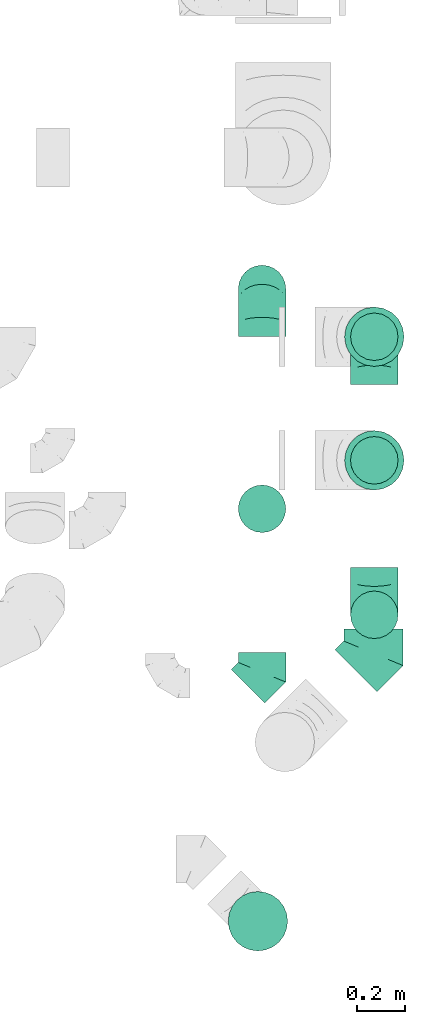
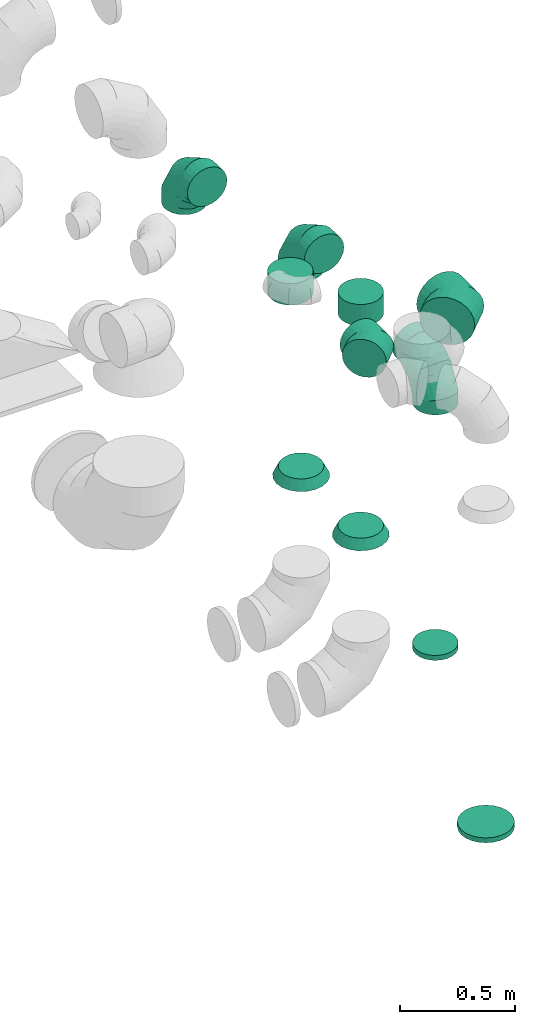
# One storey, part 47 of 59: 11 flow fittings.
"""IFC2X3 building model written with IfcOpenShell, lengths in millimetres."""

from ifc_helpers import new_model, entity, si_unit, converted_unit, derived_unit, direction, frame, origin, place, context, subcontext, project, spatial, faceted_brep, source, transform, mapped, material, type_object, type_shapes, element, save


model = new_model("IFC2X3")

# Units and contexts
model_context = context("Model", 3, precision=0.01, world=origin(), true_north=direction((6.12303176911189e-17, 1.0)))
body_context = subcontext(model_context, "Body", "Model", "MODEL_VIEW")
ifc_project = project(units=[si_unit("LENGTHUNIT", "METRE", prefix="MILLI"), si_unit("AREAUNIT", "SQUARE_METRE"), si_unit("VOLUMEUNIT", "CUBIC_METRE"), converted_unit("PLANEANGLEUNIT", "DEGREE", entity("IfcRatioMeasure", 0.0174532925199433), si_unit("PLANEANGLEUNIT", "RADIAN"), dimensions=[0, 0, 0, 0, 0, 0, 0]), si_unit("MASSUNIT", "GRAM", prefix="KILO"), derived_unit("MASSDENSITYUNIT", [(si_unit("MASSUNIT", "GRAM", prefix="KILO"), 1), (si_unit("LENGTHUNIT", "METRE"), -3)]), derived_unit("MOMENTOFINERTIAUNIT", [(si_unit("LENGTHUNIT", "METRE"), 4)]), si_unit("TIMEUNIT", "SECOND"), si_unit("FREQUENCYUNIT", "HERTZ"), si_unit("THERMODYNAMICTEMPERATUREUNIT", "DEGREE_CELSIUS"), derived_unit("THERMALTRANSMITTANCEUNIT", [(si_unit("MASSUNIT", "GRAM", prefix="KILO"), 1), (si_unit("THERMODYNAMICTEMPERATUREUNIT", "KELVIN"), -1), (si_unit("TIMEUNIT", "SECOND"), -3)]), derived_unit("VOLUMETRICFLOWRATEUNIT", [(si_unit("LENGTHUNIT", "METRE"), 3), (si_unit("TIMEUNIT", "SECOND"), -1)]), derived_unit("MASSFLOWRATEUNIT", [(si_unit("MASSUNIT", "GRAM", prefix="KILO"), 1), (si_unit("TIMEUNIT", "SECOND"), -1)]), derived_unit("ROTATIONALFREQUENCYUNIT", [(si_unit("TIMEUNIT", "SECOND"), -1)]), si_unit("ELECTRICCURRENTUNIT", "AMPERE"), si_unit("ELECTRICVOLTAGEUNIT", "VOLT"), si_unit("POWERUNIT", "WATT"), si_unit("FORCEUNIT", "NEWTON", prefix="KILO"), si_unit("ILLUMINANCEUNIT", "LUX"), si_unit("LUMINOUSFLUXUNIT", "LUMEN"), si_unit("LUMINOUSINTENSITYUNIT", "CANDELA"), derived_unit("USERDEFINED", [(si_unit("MASSUNIT", "GRAM", prefix="KILO"), -1), (si_unit("LENGTHUNIT", "METRE"), -2), (si_unit("TIMEUNIT", "SECOND"), 3), (si_unit("LUMINOUSFLUXUNIT", "LUMEN"), 1)]), derived_unit("LINEARVELOCITYUNIT", [(si_unit("LENGTHUNIT", "METRE"), 1), (si_unit("TIMEUNIT", "SECOND"), -1)]), si_unit("PRESSUREUNIT", "PASCAL"), derived_unit("USERDEFINED", [(si_unit("LENGTHUNIT", "METRE"), -2), (si_unit("MASSUNIT", "GRAM", prefix="KILO"), 1), (si_unit("TIMEUNIT", "SECOND"), -2)]), derived_unit("LINEARFORCEUNIT", [(si_unit("MASSUNIT", "GRAM", prefix="KILO"), 1), (si_unit("LENGTHUNIT", "METRE"), 1), (si_unit("TIMEUNIT", "SECOND"), -2), (si_unit("LENGTHUNIT", "METRE"), -1)]), derived_unit("PLANARFORCEUNIT", [(si_unit("MASSUNIT", "GRAM", prefix="KILO"), 1), (si_unit("LENGTHUNIT", "METRE"), 1), (si_unit("TIMEUNIT", "SECOND"), -2), (si_unit("LENGTHUNIT", "METRE"), -2)])], contexts=[model_context])

# Site, building, storey
site_placement = place(None, origin())
site = spatial("IfcSite", under=ifc_project, at=site_placement, CompositionType="ELEMENT")
building_placement = place(site_placement, origin())
building = spatial("IfcBuilding", under=site, at=building_placement, CompositionType="ELEMENT")
storey_placement = place(building_placement, frame((0.0, 0.0, 28200.0)))
storey = spatial("IfcBuildingStorey", under=building, at=storey_placement, CompositionType="ELEMENT", Elevation=28200.0)

# Flow fittings
ifc_material = material()
duct_fitting_type_1 = type_object("IfcDuctFittingType", PredefinedType="NOTDEFINED", material=ifc_material)
shared_shape_1 = source(origin(), body_context, "Body", "Brep", [
    faceted_brep([(20.0, 32.35, -120.74), (20.0, 62.5, -108.25), (20.0, 88.39, -88.39), (20.0, 108.25, -62.5), (20.0, 120.74, -32.35), (20.0, 125.0, 0.0), (20.0, 120.74, 32.35), (20.0, 108.25, 62.5), (20.0, 88.39, 88.39), (20.0, 62.5, 108.25), (20.0, 32.35, 120.74), (20.0, 0.0, 125.0), (20.0, -32.35, 120.74), (20.0, -62.5, 108.25), (20.0, -88.39, 88.39), (20.0, -108.25, 62.5), (20.0, -120.74, 32.35), (20.0, -125.0, 0.0), (20.0, -120.74, -32.35), (20.0, -108.25, -62.5), (20.0, -88.39, -88.39), (20.0, -62.5, -108.25), (20.0, -32.35, -120.74), (20.0, 0.0, -125.0), (0.0, 0.0, 125.0), (0.0, 32.35, 120.74), (-6.1, 32.35, 120.74), (-6.1, 0.0, 125.0), (0.0, 62.5, 108.25), (-6.1, 62.5, 108.25), (0.0, 88.39, 88.39), (-6.1, 88.39, 88.39), (0.0, 108.25, 62.5), (0.0, 120.74, 32.35), (-6.1, 120.74, 32.35), (-6.1, 108.25, 62.5), (0.0, 125.0, 0.0), (-6.1, 125.0, 0.0), (0.0, 120.74, -32.35), (-6.1, 120.74, -32.35), (0.0, 108.25, -62.5), (-6.1, 108.25, -62.5), (0.0, 88.39, -88.39), (-6.1, 88.39, -88.39), (0.0, 62.5, -108.25), (0.0, 32.35, -120.74), (-6.1, 32.35, -120.74), (-6.1, 62.5, -108.25), (0.0, 0.0, -125.0), (-6.1, 0.0, -125.0), (0.0, -32.35, -120.74), (-6.1, -32.35, -120.74), (0.0, -62.5, -108.25), (-6.1, -62.5, -108.25), (0.0, -88.39, -88.39), (-6.1, -88.39, -88.39), (0.0, -108.25, -62.5), (0.0, -120.74, -32.35), (-6.1, -120.74, -32.35), (-6.1, -108.25, -62.5), (0.0, -125.0, 0.0), (-6.1, -125.0, 0.0), (0.0, -120.74, 32.35), (-6.1, -120.74, 32.35), (0.0, -108.25, 62.5), (-6.1, -108.25, 62.5), (0.0, -88.39, 88.39), (-6.1, -88.39, 88.39), (0.0, -62.5, 108.25), (0.0, -32.35, 120.74), (-6.1, -32.35, 120.74), (-6.1, -62.5, 108.25)], [[[0, 1, 2, 3, 4, 5, 6, 7, 8, 9, 10, 11, 12, 13, 14, 15, 16, 17, 18, 19, 20, 21, 22, 23]], [[24, 11, 10, 25, 26, 27]], [[25, 10, 9, 28, 29, 26]], [[28, 9, 8, 30, 31, 29]], [[32, 7, 6, 33, 34, 35]], [[33, 6, 5, 36, 37, 34]], [[30, 8, 7, 32, 35, 31]], [[36, 5, 4, 38, 39, 37]], [[38, 4, 3, 40, 41, 39]], [[40, 3, 2, 42, 43, 41]], [[44, 1, 0, 45, 46, 47]], [[45, 0, 23, 48, 49, 46]], [[42, 2, 1, 44, 47, 43]], [[48, 23, 22, 50, 51, 49]], [[50, 22, 21, 52, 53, 51]], [[52, 21, 20, 54, 55, 53]], [[56, 19, 18, 57, 58, 59]], [[57, 18, 17, 60, 61, 58]], [[54, 20, 19, 56, 59, 55]], [[60, 17, 16, 62, 63, 61]], [[62, 16, 15, 64, 65, 63]], [[64, 15, 14, 66, 67, 65]], [[68, 13, 12, 69, 70, 71]], [[69, 12, 11, 24, 27, 70]], [[66, 14, 13, 68, 71, 67]], [[49, 51, 53, 55, 59, 58, 61, 63, 65, 67, 71, 70, 27, 26, 29, 31, 35, 34, 37, 39, 41, 43, 47, 46]]]),
])
type_shapes(duct_fitting_type_1, [shared_shape_1])
flow_fitting_1_placement = place(storey_placement, frame((72605.18, 8046.98, 1100.0), z_axis=(0.707106781186531, -0.707106781186564, 0.0), x_axis=(0.0, 0.0, 1.0)))
element("IfcFlowFitting", 1, at=flow_fitting_1_placement, inside=storey, type_object=duct_fitting_type_1, material=ifc_material, context=body_context, shape_type="MappedRepresentation", body=[
    mapped(shared_shape_1, transform((0.0, 0.0, 0.0), scale=1.0)),
])
duct_fitting_type_2 = type_object("IfcDuctFittingType", PredefinedType="NOTDEFINED", material=ifc_material)
shared_shape_2 = source(origin(), body_context, "Body", "Brep", [
    faceted_brep([(-200.0, 0.0, -100.0), (-200.0, -25.88, -96.59), (-200.0, -50.0, -86.6), (-200.0, -70.71, -70.71), (-200.0, -86.6, -50.0), (-200.0, -96.59, -25.88), (-200.0, -100.0, 0.0), (-200.0, -96.59, 25.88), (-200.0, -86.6, 50.0), (-200.0, -70.71, 70.71), (-200.0, -50.0, 86.6), (-200.0, -25.88, 96.59), (-200.0, 0.0, 100.0), (-200.0, 25.88, 96.59), (-200.0, 50.0, 86.6), (-200.0, 70.71, 70.71), (-200.0, 86.6, 50.0), (-200.0, 96.59, 25.88), (-200.0, 100.0, 0.0), (-200.0, 96.59, -25.88), (-200.0, 86.6, -50.0), (-200.0, 70.71, -70.71), (-200.0, 50.0, -86.6), (-200.0, 25.88, -96.59), (-153.35, 25.88, 96.59), (-159.81, 50.0, 86.6), (-146.41, 0.0, 100.0), (-165.36, 70.71, 70.71), (-172.29, 96.59, 25.88), (-173.21, 100.0, 0.0), (-169.62, 86.6, 50.0), (-169.62, 86.6, -50.0), (-165.36, 70.71, -70.71), (-172.29, 96.59, -25.88), (-153.35, 25.88, -96.59), (-146.41, 0.0, -100.0), (-159.81, 50.0, -86.6), (-139.48, -25.88, -96.59), (-133.01, -50.0, -86.6), (-127.46, -70.71, -70.71), (-123.21, -86.6, -50.0), (-120.53, -96.59, -25.88), (-119.62, -100.0, 0.0), (-120.53, -96.59, 25.88), (-123.21, -86.6, 50.0), (-127.46, -70.71, 70.71), (-133.01, -50.0, 86.6), (-139.48, -25.88, 96.59), (-72.54, 72.54, 96.59), (-90.19, 90.19, 86.6), (-53.59, 53.59, 100.0), (-105.35, 105.35, 70.71), (-116.99, 116.99, 50.0), (-124.3, 124.3, 25.88), (-126.79, 126.79, 0.0), (-124.3, 124.3, -25.88), (-116.99, 116.99, -50.0), (-105.35, 105.35, -70.71), (-72.54, 72.54, -96.59), (-53.59, 53.59, -100.0), (-90.19, 90.19, -86.6), (-34.64, 34.64, -96.59), (-16.99, 16.99, -86.6), (-1.83, 1.83, -70.71), (9.81, -9.81, -50.0), (17.12, -17.12, -25.88), (19.62, -19.62, 0.0), (17.12, -17.12, 25.88), (9.81, -9.81, 50.0), (-1.83, 1.83, 70.71), (-16.99, 16.99, 86.6), (-34.64, 34.64, 96.59), (-25.88, 153.35, 96.59), (-50.0, 159.81, 86.6), (0.0, 146.41, 100.0), (-70.71, 165.36, 70.71), (-86.6, 169.62, 50.0), (-96.59, 172.29, 25.88), (-100.0, 173.21, 0.0), (-96.59, 172.29, -25.88), (-86.6, 169.62, -50.0), (-70.71, 165.36, -70.71), (-25.88, 153.35, -96.59), (0.0, 146.41, -100.0), (-50.0, 159.81, -86.6), (25.88, 139.48, -96.59), (50.0, 133.01, -86.6), (70.71, 127.46, -70.71), (86.6, 123.21, -50.0), (96.59, 120.53, -25.88), (100.0, 119.62, 0.0), (96.59, 120.53, 25.88), (86.6, 123.21, 50.0), (70.71, 127.46, 70.71), (50.0, 133.01, 86.6), (25.88, 139.48, 96.59), (-25.88, 200.0, -96.59), (-50.0, 200.0, -86.6), (-70.71, 200.0, -70.71), (-86.6, 200.0, -50.0), (-96.59, 200.0, -25.88), (-100.0, 200.0, 0.0), (-96.59, 200.0, 25.88), (-86.6, 200.0, 50.0), (-70.71, 200.0, 70.71), (-50.0, 200.0, 86.6), (-25.88, 200.0, 96.59), (0.0, 200.0, 100.0), (25.88, 200.0, 96.59), (50.0, 200.0, 86.6), (70.71, 200.0, 70.71), (86.6, 200.0, 50.0), (96.59, 200.0, 25.88), (100.0, 200.0, 0.0), (96.59, 200.0, -25.88), (86.6, 200.0, -50.0), (70.71, 200.0, -70.71), (50.0, 200.0, -86.6), (25.88, 200.0, -96.59), (0.0, 200.0, -100.0)], [[[0, 1, 2, 3, 4, 5, 6, 7, 8, 9, 10, 11, 12, 13, 14, 15, 16, 17, 18, 19, 20, 21, 22, 23]], [[24, 25, 14, 13]], [[26, 24, 13, 12]], [[14, 25, 27, 15]], [[28, 29, 18, 17]], [[30, 28, 17, 16]], [[15, 27, 30, 16]], [[20, 31, 32, 21]], [[33, 31, 20, 19]], [[18, 29, 33, 19]], [[34, 35, 0, 23]], [[36, 34, 23, 22]], [[32, 36, 22, 21]], [[1, 0, 35, 37]], [[2, 1, 37, 38]], [[38, 39, 3, 2]], [[5, 4, 40, 41]], [[6, 5, 41, 42]], [[39, 40, 4, 3]], [[6, 42, 43, 7]], [[7, 43, 44, 8]], [[8, 44, 45, 9]], [[9, 45, 46, 10]], [[10, 46, 47, 11]], [[26, 12, 11, 47]], [[48, 49, 25, 24]], [[50, 48, 24, 26]], [[27, 25, 49, 51]], [[52, 53, 28, 30]], [[51, 52, 30, 27]], [[29, 28, 53, 54]], [[55, 56, 31, 33]], [[54, 55, 33, 29]], [[32, 31, 56, 57]], [[58, 59, 35, 34]], [[60, 58, 34, 36]], [[57, 60, 36, 32]], [[37, 35, 59, 61]], [[38, 37, 61, 62]], [[39, 38, 62, 63]], [[41, 40, 64, 65]], [[42, 41, 65, 66]], [[63, 64, 40, 39]], [[43, 42, 66, 67]], [[44, 43, 67, 68]], [[68, 69, 45, 44]], [[46, 45, 69, 70]], [[47, 46, 70, 71]], [[26, 47, 71, 50]], [[72, 73, 49, 48]], [[74, 72, 48, 50]], [[51, 49, 73, 75]], [[76, 77, 53, 52]], [[75, 76, 52, 51]], [[54, 53, 77, 78]], [[79, 80, 56, 55]], [[78, 79, 55, 54]], [[57, 56, 80, 81]], [[82, 83, 59, 58]], [[84, 82, 58, 60]], [[81, 84, 60, 57]], [[61, 59, 83, 85]], [[62, 61, 85, 86]], [[63, 62, 86, 87]], [[65, 64, 88, 89]], [[66, 65, 89, 90]], [[87, 88, 64, 63]], [[67, 66, 90, 91]], [[68, 67, 91, 92]], [[92, 93, 69, 68]], [[70, 69, 93, 94]], [[71, 70, 94, 95]], [[50, 71, 95, 74]], [[96, 97, 98, 99, 100, 101, 102, 103, 104, 105, 106, 107, 108, 109, 110, 111, 112, 113, 114, 115, 116, 117, 118, 119]], [[72, 74, 107, 106]], [[73, 72, 106, 105]], [[75, 73, 105, 104]], [[102, 101, 78, 77]], [[103, 102, 77, 76]], [[75, 104, 103, 76]], [[78, 101, 100, 79]], [[79, 100, 99, 80]], [[80, 99, 98, 81]], [[84, 97, 96, 82]], [[82, 96, 119, 83]], [[84, 81, 98, 97]], [[118, 117, 86, 85]], [[119, 118, 85, 83]], [[116, 87, 86, 117]], [[88, 115, 114, 89]], [[89, 114, 113, 90]], [[115, 88, 87, 116]], [[91, 90, 113, 112]], [[92, 91, 112, 111]], [[111, 110, 93, 92]], [[95, 94, 109, 108]], [[74, 95, 108, 107]], [[110, 109, 94, 93]]]),
])
type_shapes(duct_fitting_type_2, [shared_shape_2])
for number, where, z_axis, x_axis in (
    (2, (72622.63, 10707.48, 3000.0), (-1.0, 0.0, 0.0), (0.0, 1.0, 0.0)),
    (3, (73094.97, 10506.36, 2600.0), (-1.0, 0.0, 0.0), (0.0, 1.0, 0.0)),
    (4, (73094.97, 9336.36, 2600.0), (1.0, 0.0, 0.0), (0.0, -1.0, 0.0)),
):
    element("IfcFlowFitting", number, at=place(storey_placement, frame(where, z_axis=z_axis, x_axis=x_axis)), inside=storey, type_object=duct_fitting_type_2, material=ifc_material, context=body_context, shape_type="MappedRepresentation", body=[
        mapped(shared_shape_2, transform((0.0, 0.0, 0.0), scale=1.0)),
    ])
duct_fitting_type_3 = type_object("IfcDuctFittingType", PredefinedType="NOTDEFINED", material=ifc_material)
shared_shape_3 = source(origin(), body_context, "Body", "Brep", [
    faceted_brep([(-82.84, 0.0, -100.0), (-82.84, -25.88, -96.59), (-82.84, -50.0, -86.6), (-82.84, -70.71, -70.71), (-82.84, -86.6, -50.0), (-82.84, -96.59, -25.88), (-82.84, -100.0, 0.0), (-82.84, -96.59, 25.88), (-82.84, -86.6, 50.0), (-82.84, -70.71, 70.71), (-82.84, -50.0, 86.6), (-82.84, -25.88, 96.59), (-82.84, 0.0, 100.0), (-82.84, 25.88, 96.59), (-82.84, 50.0, 86.6), (-82.84, 70.71, 70.71), (-82.84, 86.6, 50.0), (-82.84, 96.59, 25.88), (-82.84, 100.0, 0.0), (-82.84, 96.59, -25.88), (-82.84, 86.6, -50.0), (-82.84, 70.71, -70.71), (-82.84, 50.0, -86.6), (-82.84, 25.88, -96.59), (-10.72, 25.88, 96.59), (-20.71, 50.0, 86.6), (0.0, 0.0, 100.0), (-29.29, 70.71, 70.71), (-35.87, 86.6, 50.0), (-40.01, 96.59, 25.88), (-41.42, 100.0, 0.0), (-40.01, 96.59, -25.88), (-35.87, 86.6, -50.0), (-29.29, 70.71, -70.71), (-10.72, 25.88, -96.59), (0.0, 0.0, -100.0), (-20.71, 50.0, -86.6), (10.72, -25.88, -96.59), (20.71, -50.0, -86.6), (29.29, -70.71, -70.71), (35.87, -86.6, -50.0), (40.01, -96.59, -25.88), (41.42, -100.0, 0.0), (40.01, -96.59, 25.88), (35.87, -86.6, 50.0), (29.29, -70.71, 70.71), (20.71, -50.0, 86.6), (10.72, -25.88, 96.59), (58.58, 58.58, 100.0), (40.28, 76.88, 96.59), (23.22, 93.93, 86.6), (8.58, 108.58, 70.71), (-2.66, 119.82, 50.0), (-9.72, 126.88, 25.88), (-12.13, 129.29, 0.0), (-9.72, 126.88, -25.88), (-2.66, 119.82, -50.0), (8.58, 108.58, -70.71), (23.22, 93.93, -86.6), (40.28, 76.88, -96.59), (58.58, 58.58, -100.0), (76.88, 40.28, -96.59), (93.93, 23.22, -86.6), (108.58, 8.58, -70.71), (119.82, -2.66, -50.0), (126.88, -9.72, -25.88), (129.29, -12.13, 0.0), (126.88, -9.72, 25.88), (119.82, -2.66, 50.0), (108.58, 8.58, 70.71), (93.93, 23.22, 86.6), (76.88, 40.28, 96.59)], [[[0, 1, 2, 3, 4, 5, 6, 7, 8, 9, 10, 11, 12, 13, 14, 15, 16, 17, 18, 19, 20, 21, 22, 23]], [[24, 25, 14, 13]], [[26, 24, 13, 12]], [[14, 25, 27, 15]], [[28, 29, 17, 16]], [[28, 16, 15, 27]], [[30, 18, 17, 29]], [[31, 32, 20, 19]], [[30, 31, 19, 18]], [[32, 33, 21, 20]], [[34, 35, 0, 23]], [[36, 34, 23, 22]], [[33, 36, 22, 21]], [[1, 0, 35, 37]], [[2, 1, 37, 38]], [[38, 39, 3, 2]], [[5, 4, 40, 41]], [[6, 5, 41, 42]], [[39, 40, 4, 3]], [[6, 42, 43, 7]], [[7, 43, 44, 8]], [[8, 44, 45, 9]], [[9, 45, 46, 10]], [[10, 46, 47, 11]], [[26, 12, 11, 47]], [[24, 26, 48, 49]], [[25, 24, 49, 50]], [[27, 25, 50, 51]], [[29, 28, 52, 53]], [[30, 29, 53, 54]], [[51, 52, 28, 27]], [[30, 54, 55, 31]], [[31, 55, 56, 32]], [[57, 33, 32, 56]], [[36, 58, 59, 34]], [[34, 59, 60, 35]], [[58, 36, 33, 57]], [[35, 60, 61, 37]], [[37, 61, 62, 38]], [[63, 39, 38, 62]], [[40, 64, 65, 41]], [[41, 65, 66, 42]], [[64, 40, 39, 63]], [[43, 42, 66, 67]], [[44, 43, 67, 68]], [[68, 69, 45, 44]], [[47, 46, 70, 71]], [[26, 47, 71, 48]], [[69, 70, 46, 45]], [[59, 58, 57, 56, 55, 54, 53, 52, 51, 50, 49, 48, 71, 70, 69, 68, 67, 66, 65, 64, 63, 62, 61, 60]]]),
])
type_shapes(duct_fitting_type_3, [shared_shape_3])
flow_fitting_2_placement = place(storey_placement, frame((72622.63, 9094.58, 3000.0), z_axis=(-1.64028633394854e-07, 0.0, 1.0), x_axis=(0.707106781186601, 0.707106781186485, 1.15985758982274e-07)))
element("IfcFlowFitting", 5, at=flow_fitting_2_placement, inside=storey, type_object=duct_fitting_type_3, material=ifc_material, context=body_context, shape_type="MappedRepresentation", body=[
    mapped(shared_shape_3, transform((0.0, 0.0, 0.0), scale=1.0)),
])
duct_fitting_type_4 = type_object("IfcDuctFittingType", PredefinedType="NOTDEFINED", material=ifc_material)
shared_shape_4 = source(origin(), body_context, "Body", "Brep", [
    faceted_brep([(20.0, 0.0, -100.0), (20.0, 25.88, -96.59), (20.0, 50.0, -86.6), (20.0, 70.71, -70.71), (20.0, 86.6, -50.0), (20.0, 96.59, -25.88), (20.0, 100.0, 0.0), (20.0, 96.59, 25.88), (20.0, 86.6, 50.0), (20.0, 70.71, 70.71), (20.0, 50.0, 86.6), (20.0, 25.88, 96.59), (20.0, 0.0, 100.0), (20.0, -25.88, 96.59), (20.0, -50.0, 86.6), (20.0, -70.71, 70.71), (20.0, -86.6, 50.0), (20.0, -96.59, 25.88), (20.0, -100.0, 0.0), (20.0, -96.59, -25.88), (20.0, -86.6, -50.0), (20.0, -70.71, -70.71), (20.0, -50.0, -86.6), (20.0, -25.88, -96.59), (0.0, 0.0, 100.0), (-6.1, 0.0, 100.0), (-6.1, -25.88, 96.59), (0.0, -25.88, 96.59), (-6.1, -50.0, 86.6), (0.0, -50.0, 86.6), (0.0, -70.71, 70.71), (-6.1, -70.71, 70.71), (0.0, -86.6, 50.0), (-6.1, -86.6, 50.0), (-6.1, -96.59, 25.88), (0.0, -96.59, 25.88), (-6.1, -100.0, 0.0), (0.0, -100.0, 0.0), (-6.1, -96.59, -25.88), (0.0, -96.59, -25.88), (-6.1, -86.6, -50.0), (0.0, -86.6, -50.0), (0.0, -70.71, -70.71), (-6.1, -70.71, -70.71), (0.0, -50.0, -86.6), (-6.1, -50.0, -86.6), (-6.1, -25.88, -96.59), (0.0, -25.88, -96.59), (-6.1, 0.0, -100.0), (0.0, 0.0, -100.0), (-6.1, 25.88, -96.59), (0.0, 25.88, -96.59), (-6.1, 50.0, -86.6), (0.0, 50.0, -86.6), (0.0, 70.71, -70.71), (-6.1, 70.71, -70.71), (0.0, 86.6, -50.0), (-6.1, 86.6, -50.0), (-6.1, 96.59, -25.88), (0.0, 96.59, -25.88), (-6.1, 100.0, 0.0), (0.0, 100.0, 0.0), (-6.1, 96.59, 25.88), (0.0, 96.59, 25.88), (-6.1, 86.6, 50.0), (0.0, 86.6, 50.0), (0.0, 70.71, 70.71), (-6.1, 70.71, 70.71), (0.0, 50.0, 86.6), (-6.1, 50.0, 86.6), (-6.1, 25.88, 96.59), (0.0, 25.88, 96.59)], [[[0, 1, 2, 3, 4, 5, 6, 7, 8, 9, 10, 11, 12, 13, 14, 15, 16, 17, 18, 19, 20, 21, 22, 23]], [[13, 12, 24, 25, 26, 27]], [[14, 13, 27, 26, 28, 29]], [[30, 15, 14, 29, 28, 31]], [[17, 16, 32, 33, 34, 35]], [[18, 17, 35, 34, 36, 37]], [[32, 16, 15, 30, 31, 33]], [[19, 18, 37, 36, 38, 39]], [[20, 19, 39, 38, 40, 41]], [[42, 21, 20, 41, 40, 43]], [[23, 22, 44, 45, 46, 47]], [[0, 23, 47, 46, 48, 49]], [[44, 22, 21, 42, 43, 45]], [[1, 0, 49, 48, 50, 51]], [[2, 1, 51, 50, 52, 53]], [[54, 3, 2, 53, 52, 55]], [[5, 4, 56, 57, 58, 59]], [[6, 5, 59, 58, 60, 61]], [[56, 4, 3, 54, 55, 57]], [[7, 6, 61, 60, 62, 63]], [[8, 7, 63, 62, 64, 65]], [[66, 9, 8, 65, 64, 67]], [[11, 10, 68, 69, 70, 71]], [[12, 11, 71, 70, 25, 24]], [[68, 10, 9, 66, 67, 69]], [[46, 45, 43, 40, 38, 36, 34, 33, 31, 28, 26, 25, 70, 69, 67, 64, 62, 60, 58, 57, 55, 52, 50, 48]]]),
])
type_shapes(duct_fitting_type_4, [shared_shape_4])
flow_fitting_3_placement = place(storey_placement, frame((73094.97, 9336.36, 1100.0), z_axis=(0.0, -1.0, 0.0), x_axis=(0.0, 0.0, 1.0)))
element("IfcFlowFitting", 6, at=flow_fitting_3_placement, inside=storey, type_object=duct_fitting_type_4, material=ifc_material, context=body_context, shape_type="MappedRepresentation", body=[
    mapped(shared_shape_4, transform((0.0, 0.0, 0.0), scale=1.0)),
])
duct_fitting_type_5 = type_object("IfcDuctFittingType", PredefinedType="NOTDEFINED", material=ifc_material)
shared_shape_5 = source(origin(), body_context, "Body", "Brep", [
    faceted_brep([(-103.55, 0.0, -125.0), (-103.55, -32.35, -120.74), (-103.55, -62.5, -108.25), (-103.55, -88.39, -88.39), (-103.55, -108.25, -62.5), (-103.55, -120.74, -32.35), (-103.55, -125.0, 0.0), (-103.55, -120.74, 32.35), (-103.55, -108.25, 62.5), (-103.55, -88.39, 88.39), (-103.55, -62.5, 108.25), (-103.55, -32.35, 120.74), (-103.55, 0.0, 125.0), (-103.55, 32.35, 120.74), (-103.55, 62.5, 108.25), (-103.55, 88.39, 88.39), (-103.55, 108.25, 62.5), (-103.55, 120.74, 32.35), (-103.55, 125.0, 0.0), (-103.55, 120.74, -32.35), (-103.55, 108.25, -62.5), (-103.55, 88.39, -88.39), (-103.55, 62.5, -108.25), (-103.55, 32.35, -120.74), (-13.4, 32.35, 120.74), (-25.89, 62.5, 108.25), (0.0, 0.0, 125.0), (-36.61, 88.39, 88.39), (-44.84, 108.25, 62.5), (-50.01, 120.74, 32.35), (-51.78, 125.0, 0.0), (-50.01, 120.74, -32.35), (-44.84, 108.25, -62.5), (-36.61, 88.39, -88.39), (-13.4, 32.35, -120.74), (0.0, 0.0, -125.0), (-25.89, 62.5, -108.25), (13.4, -32.35, -120.74), (25.89, -62.5, -108.25), (36.61, -88.39, -88.39), (44.84, -108.25, -62.5), (50.01, -120.74, -32.35), (51.78, -125.0, 0.0), (50.01, -120.74, 32.35), (44.84, -108.25, 62.5), (36.61, -88.39, 88.39), (25.89, -62.5, 108.25), (13.4, -32.35, 120.74), (73.22, 73.22, 125.0), (50.35, 96.1, 120.74), (29.03, 117.42, 108.25), (10.72, 135.72, 88.39), (-3.32, 149.77, 62.5), (-12.15, 158.6, 32.35), (-15.17, 161.61, 0.0), (-12.15, 158.6, -32.35), (-3.32, 149.77, -62.5), (10.72, 135.72, -88.39), (29.03, 117.42, -108.25), (50.35, 96.1, -120.74), (73.22, 73.22, -125.0), (96.1, 50.35, -120.74), (117.42, 29.03, -108.25), (135.72, 10.72, -88.39), (149.77, -3.32, -62.5), (158.6, -12.15, -32.35), (161.61, -15.17, 0.0), (158.6, -12.15, 32.35), (149.77, -3.32, 62.5), (135.72, 10.72, 88.39), (117.42, 29.03, 108.25), (96.1, 50.35, 120.74)], [[[0, 1, 2, 3, 4, 5, 6, 7, 8, 9, 10, 11, 12, 13, 14, 15, 16, 17, 18, 19, 20, 21, 22, 23]], [[24, 25, 14, 13]], [[26, 24, 13, 12]], [[14, 25, 27, 15]], [[28, 29, 17, 16]], [[28, 16, 15, 27]], [[30, 18, 17, 29]], [[31, 32, 20, 19]], [[30, 31, 19, 18]], [[32, 33, 21, 20]], [[34, 35, 0, 23]], [[36, 34, 23, 22]], [[33, 36, 22, 21]], [[1, 0, 35, 37]], [[2, 1, 37, 38]], [[38, 39, 3, 2]], [[5, 4, 40, 41]], [[6, 5, 41, 42]], [[39, 40, 4, 3]], [[6, 42, 43, 7]], [[7, 43, 44, 8]], [[8, 44, 45, 9]], [[9, 45, 46, 10]], [[10, 46, 47, 11]], [[26, 12, 11, 47]], [[24, 26, 48, 49]], [[25, 24, 49, 50]], [[27, 25, 50, 51]], [[29, 28, 52, 53]], [[30, 29, 53, 54]], [[51, 52, 28, 27]], [[30, 54, 55, 31]], [[31, 55, 56, 32]], [[57, 33, 32, 56]], [[36, 58, 59, 34]], [[34, 59, 60, 35]], [[58, 36, 33, 57]], [[35, 60, 61, 37]], [[37, 61, 62, 38]], [[63, 39, 38, 62]], [[40, 64, 65, 41]], [[41, 65, 66, 42]], [[64, 40, 39, 63]], [[43, 42, 66, 67]], [[44, 43, 67, 68]], [[68, 69, 45, 44]], [[47, 46, 70, 71]], [[26, 47, 71, 48]], [[69, 70, 46, 45]], [[59, 58, 57, 56, 55, 54, 53, 52, 51, 50, 49, 48, 71, 70, 69, 68, 67, 66, 65, 64, 63, 62, 61, 60]]]),
])
type_shapes(duct_fitting_type_5, [shared_shape_5])
flow_fitting_4_placement = place(storey_placement, frame((73091.81, 9174.07, 3000.0), z_axis=(0.0, 0.0, 1.0), x_axis=(0.70710678118656, 0.707106781186535, 0.0)))
element("IfcFlowFitting", 7, at=flow_fitting_4_placement, inside=storey, type_object=duct_fitting_type_5, material=ifc_material, context=body_context, shape_type="MappedRepresentation", body=[
    mapped(shared_shape_5, transform((0.0, 0.0, 0.0), scale=1.0)),
])
duct_fitting_type_6 = type_object("IfcDuctFittingType", PredefinedType="NOTDEFINED", material=ifc_material)
shared_shape_6 = source(origin(), body_context, "Body", "Brep", [
    faceted_brep([(50.0, -73.47, -101.13), (50.0, -38.63, -118.88), (50.0, 0.0, -125.0), (50.0, 38.63, -118.88), (50.0, 73.47, -101.13), (50.0, 101.13, -73.47), (50.0, 118.88, -38.63), (50.0, 125.0, 0.0), (50.0, 118.88, 38.63), (50.0, 101.13, 73.47), (50.0, 73.47, 101.13), (50.0, 38.63, 118.88), (50.0, 0.0, 125.0), (50.0, -38.63, 118.88), (50.0, -73.47, 101.13), (50.0, -101.13, 73.47), (50.0, -118.88, 38.63), (50.0, -125.0, 0.0), (50.0, -118.88, -38.63), (50.0, -101.13, -73.47), (0.0, 30.9, -95.11), (0.0, 0.0, -100.0), (0.0, -30.9, -95.11), (0.0, -58.78, -80.9), (0.0, -80.9, -58.78), (0.0, -95.11, -30.9), (0.0, -100.0, 0.0), (0.0, -95.11, 30.9), (0.0, -80.9, 58.78), (0.0, -58.78, 80.9), (0.0, -30.9, 95.11), (0.0, 0.0, 100.0), (0.0, 30.9, 95.11), (0.0, 58.78, 80.9), (0.0, 80.9, 58.78), (0.0, 95.11, 30.9), (0.0, 100.0, 0.0), (0.0, 95.11, -30.9), (0.0, 80.9, -58.78), (0.0, 58.78, -80.9)], [[[0, 1, 2, 3, 4, 5, 6, 7, 8, 9, 10, 11, 12, 13, 14, 15, 16, 17, 18, 19]], [[20, 21, 22, 23, 24, 25, 26, 27, 28, 29, 30, 31, 32, 33, 34, 35, 36, 37, 38, 39]], [[35, 34, 9, 8]], [[36, 35, 8, 7]], [[34, 33, 10, 9]], [[10, 33, 32, 11]], [[11, 32, 31, 12]], [[30, 29, 14, 13]], [[31, 30, 13, 12]], [[29, 28, 15, 14]], [[15, 28, 27, 16]], [[16, 27, 26, 17]], [[25, 24, 19, 18]], [[26, 25, 18, 17]], [[24, 23, 0, 19]], [[0, 23, 22, 1]], [[1, 22, 21, 2]], [[20, 39, 4, 3]], [[21, 20, 3, 2]], [[39, 38, 5, 4]], [[5, 38, 37, 6]], [[6, 37, 36, 7]]]),
])
type_shapes(duct_fitting_type_6, [shared_shape_6])
for number, where, z_axis, x_axis in (
    (8, (73094.97, 10506.36, 1350.0), (0.0, -1.0, 0.0), (0.0, 0.0, -1.0)),
    (9, (73094.97, 9986.36, 1350.0), (0.0, -1.0, 0.0), (0.0, 0.0, -1.0)),
):
    element("IfcFlowFitting", number, at=place(storey_placement, frame(where, z_axis=z_axis, x_axis=x_axis)), inside=storey, type_object=duct_fitting_type_6, material=ifc_material, context=body_context, shape_type="MappedRepresentation", body=[
        mapped(shared_shape_6, transform((0.0, 0.0, 0.0), scale=1.0)),
    ])
duct_fitting_type_7 = type_object("IfcDuctFittingType", PredefinedType="NOTDEFINED", material=ifc_material)
shared_shape_7 = source(origin(), body_context, "Body", "Brep", [
    faceted_brep([(20.0, 0.0, -100.0), (20.0, 25.88, -96.59), (20.0, 50.0, -86.6), (20.0, 70.71, -70.71), (20.0, 86.6, -50.0), (20.0, 96.59, -25.88), (20.0, 100.0, 0.0), (20.0, 96.59, 25.88), (20.0, 86.6, 50.0), (20.0, 70.71, 70.71), (20.0, 50.0, 86.6), (20.0, 25.88, 96.59), (20.0, 0.0, 100.0), (20.0, -25.88, 96.59), (20.0, -50.0, 86.6), (20.0, -70.71, 70.71), (20.0, -86.6, 50.0), (20.0, -96.59, 25.88), (20.0, -100.0, 0.0), (20.0, -96.59, -25.88), (20.0, -86.6, -50.0), (20.0, -70.71, -70.71), (20.0, -50.0, -86.6), (20.0, -25.88, -96.59), (0.0, 0.0, 100.0), (-93.9, 0.0, 100.0), (-93.9, -25.88, 96.59), (0.0, -25.88, 96.59), (-93.9, -50.0, 86.6), (0.0, -50.0, 86.6), (0.0, -70.71, 70.71), (-93.9, -70.71, 70.71), (0.0, -86.6, 50.0), (-93.9, -86.6, 50.0), (-93.9, -96.59, 25.88), (0.0, -96.59, 25.88), (-93.9, -100.0, 0.0), (0.0, -100.0, 0.0), (-93.9, -96.59, -25.88), (0.0, -96.59, -25.88), (-93.9, -86.6, -50.0), (0.0, -86.6, -50.0), (0.0, -70.71, -70.71), (-93.9, -70.71, -70.71), (0.0, -50.0, -86.6), (-93.9, -50.0, -86.6), (-93.9, -25.88, -96.59), (0.0, -25.88, -96.59), (-93.9, 0.0, -100.0), (0.0, 0.0, -100.0), (-93.9, 25.88, -96.59), (0.0, 25.88, -96.59), (-93.9, 50.0, -86.6), (0.0, 50.0, -86.6), (0.0, 70.71, -70.71), (-93.9, 70.71, -70.71), (0.0, 86.6, -50.0), (-93.9, 86.6, -50.0), (-93.9, 96.59, -25.88), (0.0, 96.59, -25.88), (-93.9, 100.0, 0.0), (0.0, 100.0, 0.0), (-93.9, 96.59, 25.88), (0.0, 96.59, 25.88), (-93.9, 86.6, 50.0), (0.0, 86.6, 50.0), (0.0, 70.71, 70.71), (-93.9, 70.71, 70.71), (0.0, 50.0, 86.6), (-93.9, 50.0, 86.6), (-93.9, 25.88, 96.59), (0.0, 25.88, 96.59)], [[[0, 1, 2, 3, 4, 5, 6, 7, 8, 9, 10, 11, 12, 13, 14, 15, 16, 17, 18, 19, 20, 21, 22, 23]], [[13, 12, 24, 25, 26, 27]], [[14, 13, 27, 26, 28, 29]], [[30, 15, 14, 29, 28, 31]], [[17, 16, 32, 33, 34, 35]], [[18, 17, 35, 34, 36, 37]], [[32, 16, 15, 30, 31, 33]], [[19, 18, 37, 36, 38, 39]], [[20, 19, 39, 38, 40, 41]], [[42, 21, 20, 41, 40, 43]], [[23, 22, 44, 45, 46, 47]], [[0, 23, 47, 46, 48, 49]], [[44, 22, 21, 42, 43, 45]], [[1, 0, 49, 48, 50, 51]], [[2, 1, 51, 50, 52, 53]], [[54, 3, 2, 53, 52, 55]], [[5, 4, 56, 57, 58, 59]], [[6, 5, 59, 58, 60, 61]], [[56, 4, 3, 54, 55, 57]], [[7, 6, 61, 60, 62, 63]], [[8, 7, 63, 62, 64, 65]], [[66, 9, 8, 65, 64, 67]], [[11, 10, 68, 69, 70, 71]], [[12, 11, 71, 70, 25, 24]], [[68, 10, 9, 66, 67, 69]], [[46, 45, 43, 40, 38, 36, 34, 33, 31, 28, 26, 25, 70, 69, 67, 64, 62, 60, 58, 57, 55, 52, 50, 48]]]),
])
type_shapes(duct_fitting_type_7, [shared_shape_7])
for number, where, z_axis, x_axis in (
    (10, (72622.63, 9782.48, 2900.0), (0.0, 1.0, 0.0), (0.0, 0.0, -1.0)),
    (11, (73094.97, 9986.36, 2500.0), (0.0, -1.0, 0.0), (0.0, 0.0, -1.0)),
):
    element("IfcFlowFitting", number, at=place(storey_placement, frame(where, z_axis=z_axis, x_axis=x_axis)), inside=storey, type_object=duct_fitting_type_7, material=ifc_material, context=body_context, shape_type="MappedRepresentation", body=[
        mapped(shared_shape_7, transform((0.0, 0.0, 0.0), scale=1.0)),
    ])

save(model, "model.ifc")
